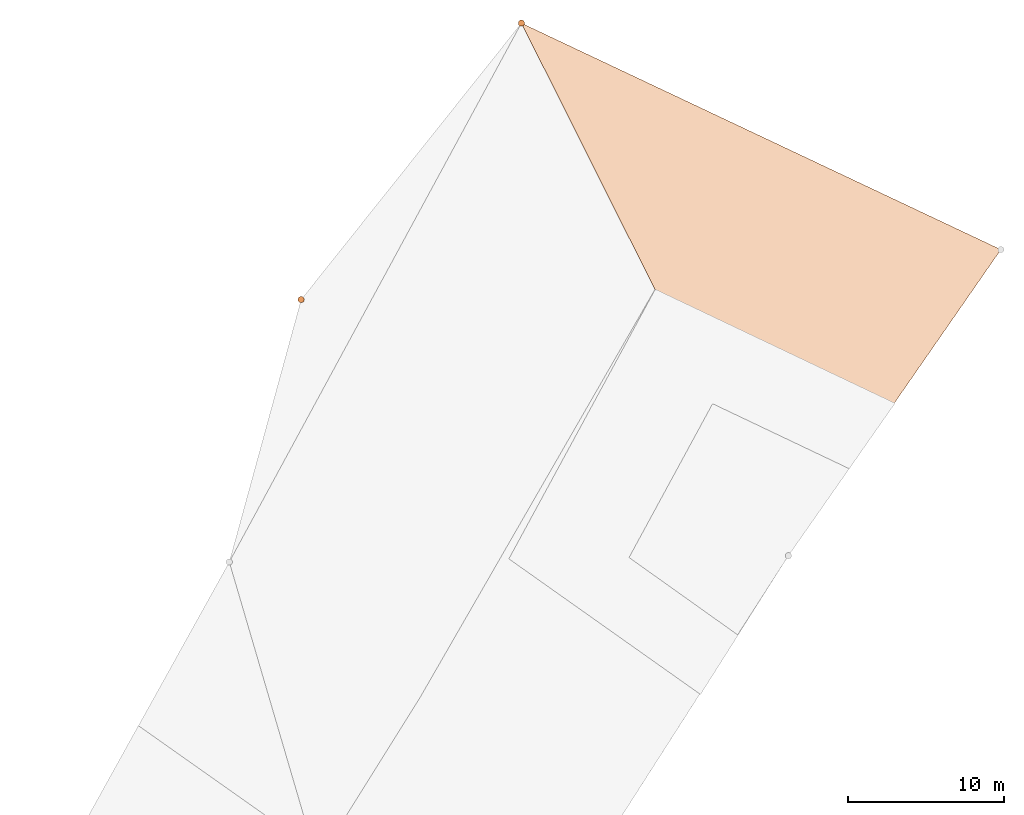
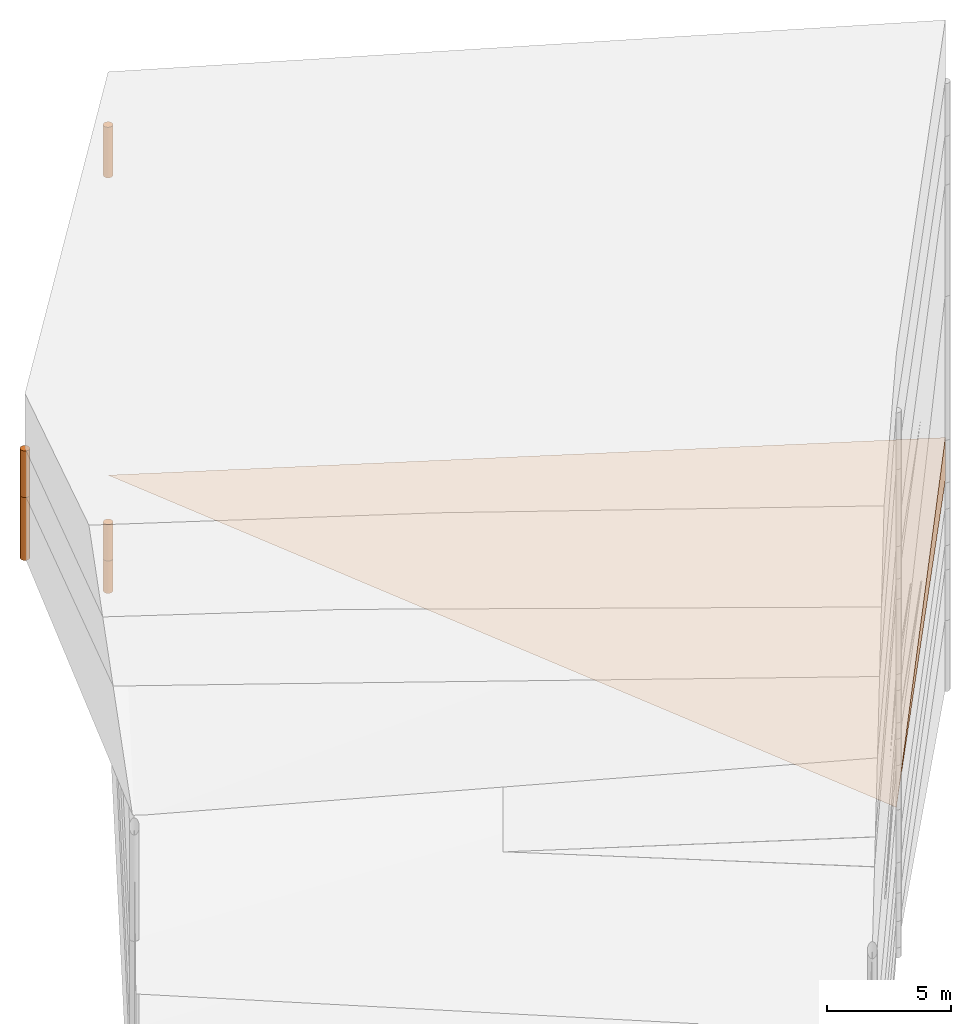
# One storey, part 17 of 24: 6 geographic elements.
"""IFC4 building model written with IfcOpenShell, lengths in metres."""

from ifc_helpers import new_model, entity, si_unit, converted_unit, frame, origin_with_axes, origin_2d_with_axis, place, context, subcontext, project, spatial, polygons, element, save


model = new_model("IFC4")

# Units and contexts
model_context = context("Model", 3, precision=1e-05, world=origin_with_axes())
plan_context = context("Plan", 2, precision=1e-05, world=origin_2d_with_axis())
body_context = subcontext(model_context, "Body", "Model", "MODEL_VIEW")
ifc_project = project(units=[converted_unit("PLANEANGLEUNIT", "degree", entity("IfcReal", 0.0174532925199433), si_unit("PLANEANGLEUNIT", "RADIAN"), dimensions=[0, 0, 0, 0, 0, 0, 0]), si_unit("AREAUNIT", "SQUARE_METRE"), si_unit("VOLUMEUNIT", "CUBIC_METRE"), si_unit("LENGTHUNIT", "METRE")], contexts=[model_context, plan_context])

# Site, building, storey
site_placement = place(None, origin_with_axes())
site = spatial("IfcSite", under=ifc_project, at=site_placement)
building_placement = place(site_placement, origin_with_axes())
building = spatial("IfcBuilding", under=site, at=building_placement, Name="Building")
storey_placement = place(building_placement, origin_with_axes())
storey = spatial("IfcBuildingStorey", under=building, at=storey_placement, Name="Storey")

# Geographic elements
geographic_element_1_placement = place(storey_placement, frame((42.3506698608398, 73.5637969970703, -2.76223611831665), z_axis=(0.0, 0.0, 1.0), x_axis=(1.0, 0.0, 0.0)))
element("IfcGeographicElement", 1, at=geographic_element_1_placement, inside=storey, PredefinedType="NOTDEFINED", context=body_context, shape_type="Tessellation", body=[
    polygons([(-22.9506683349609, 17.33620262146, 1.76223838329315), (7.74932813644409, 2.83620429039001, -0.437762945890427), (7.74932813644409, 2.83620429039001, 1.66223680973053), (-5.850670337677, -16.7637958526611, 0.0622363053262234)], [[[3, 4, 2]], [[1, 2, 4]], [[1, 4, 3]], [[2, 1, 3]]]),
])
geographic_element_2_placement = place(storey_placement, frame((5.30000019073486, 73.1999969482422, 14.8500003814697), z_axis=(0.0, 0.0, 1.0), x_axis=(1.0, 0.0, 0.0)))
element("IfcGeographicElement", 2, at=geographic_element_2_placement, inside=storey, PredefinedType="NOTDEFINED", context=body_context, shape_type="Tessellation", body=[
    polygons([(0.0, 0.0, -1.14999985694885), (0.0390180610120296, 0.196157038211823, -1.14999985694885), (0.0, 0.199999988079071, -1.14999985694885), (0.0, 0.0, 1.14999985694885), (0.0, 0.199999988079071, 1.14999985694885), (0.0390180610120296, 0.196157038211823, 1.14999985694885), (0.0765366926789284, 0.18477588891983, -1.14999985694885), (0.0765366926789284, 0.18477588891983, 1.14999985694885), (0.111114047467709, 0.166293919086456, -1.14999985694885), (0.111114047467709, 0.166293919086456, 1.14999985694885), (0.141421362757683, 0.141421362757683, -1.14999985694885), (0.141421362757683, 0.141421362757683, 1.14999985694885), (0.166293919086456, 0.111114047467709, -1.14999985694885), (0.166293919086456, 0.111114047467709, 1.14999985694885), (0.18477588891983, 0.0765366926789284, -1.14999985694885), (0.18477588891983, 0.0765366926789284, 1.14999985694885), (0.196157038211823, 0.0390180610120296, -1.14999985694885), (0.196157038211823, 0.0390180610120296, 1.14999985694885), (0.199999988079071, 0.0, -1.14999985694885), (0.199999988079071, 0.0, 1.14999985694885), (0.196157038211823, -0.0390180610120296, -1.14999985694885), (0.196157038211823, -0.0390180610120296, 1.14999985694885), (0.18477588891983, -0.0765366926789284, -1.14999985694885), (0.18477588891983, -0.0765366926789284, 1.14999985694885), (0.166293919086456, -0.111114047467709, -1.14999985694885), (0.166293919086456, -0.111114047467709, 1.14999985694885), (0.141421362757683, -0.141421362757683, -1.14999985694885), (0.141421362757683, -0.141421362757683, 1.14999985694885), (0.111114047467709, -0.166293919086456, -1.14999985694885), (0.111114047467709, -0.166293919086456, 1.14999985694885), (0.0765366926789284, -0.18477588891983, -1.14999985694885), (0.0765366926789284, -0.18477588891983, 1.14999985694885), (0.0390180610120296, -0.196157038211823, -1.14999985694885), (0.0390180610120296, -0.196157038211823, 1.14999985694885), (0.0, -0.199999988079071, -1.14999985694885), (0.0, -0.199999988079071, 1.14999985694885), (-0.0390180610120296, -0.196157038211823, -1.14999985694885), (-0.0390180610120296, -0.196157038211823, 1.14999985694885), (-0.0765366926789284, -0.18477588891983, -1.14999985694885), (-0.0765366926789284, -0.18477588891983, 1.14999985694885), (-0.111114047467709, -0.166293919086456, -1.14999985694885), (-0.111114047467709, -0.166293919086456, 1.14999985694885), (-0.141421362757683, -0.141421362757683, -1.14999985694885), (-0.141421362757683, -0.141421362757683, 1.14999985694885), (-0.166293919086456, -0.111114047467709, -1.14999985694885), (-0.166293919086456, -0.111114047467709, 1.14999985694885), (-0.18477588891983, -0.0765366926789284, -1.14999985694885), (-0.18477588891983, -0.0765366926789284, 1.14999985694885), (-0.196157038211823, -0.0390180610120296, -1.14999985694885), (-0.196157038211823, -0.0390180610120296, 1.14999985694885), (-0.199999988079071, 0.0, -1.14999985694885), (-0.199999988079071, 0.0, 1.14999985694885), (-0.196157038211823, 0.0390180610120296, -1.14999985694885), (-0.196157038211823, 0.0390180610120296, 1.14999985694885), (-0.18477588891983, 0.0765366926789284, -1.14999985694885), (-0.18477588891983, 0.0765366926789284, 1.14999985694885), (-0.166293919086456, 0.111114047467709, -1.14999985694885), (-0.166293919086456, 0.111114047467709, 1.14999985694885), (-0.141421362757683, 0.141421362757683, -1.14999985694885), (-0.141421362757683, 0.141421362757683, 1.14999985694885), (-0.111114047467709, 0.166293919086456, -1.14999985694885), (-0.111114047467709, 0.166293919086456, 1.14999985694885), (-0.0765366926789284, 0.18477588891983, -1.14999985694885), (-0.0765366926789284, 0.18477588891983, 1.14999985694885), (-0.0390180610120296, 0.196157038211823, -1.14999985694885), (-0.0390180610120296, 0.196157038211823, 1.14999985694885)], [[[3, 2, 1]], [[6, 5, 4]], [[28, 30, 29, 27]], [[2, 7, 1]], [[8, 6, 4]], [[64, 66, 65, 63]], [[7, 9, 1]], [[10, 8, 4]], [[9, 11, 1]], [[12, 10, 4]], [[6, 8, 7, 2]], [[1, 11, 13]], [[12, 4, 14]], [[66, 5, 3, 65]], [[1, 13, 15]], [[4, 16, 14]], [[12, 14, 13, 11]], [[1, 15, 17]], [[16, 4, 18]], [[14, 16, 15, 13]], [[1, 17, 19]], [[18, 4, 20]], [[16, 18, 17, 15]], [[1, 19, 21]], [[20, 4, 22]], [[18, 20, 19, 17]], [[1, 21, 23]], [[22, 4, 24]], [[20, 22, 21, 19]], [[1, 23, 25]], [[4, 26, 24]], [[22, 24, 23, 21]], [[27, 1, 25]], [[4, 28, 26]], [[24, 26, 25, 23]], [[1, 27, 29]], [[28, 4, 30]], [[26, 28, 27, 25]], [[1, 29, 31]], [[4, 32, 30]], [[5, 6, 2, 3]], [[1, 31, 33]], [[4, 34, 32]], [[30, 32, 31, 29]], [[1, 33, 35]], [[4, 36, 34]], [[8, 10, 9, 7]], [[1, 35, 37]], [[4, 38, 36]], [[32, 34, 33, 31]], [[1, 37, 39]], [[4, 40, 38]], [[36, 38, 37, 35]], [[1, 39, 41]], [[4, 42, 40]], [[38, 40, 39, 37]], [[43, 1, 41]], [[4, 44, 42]], [[40, 42, 41, 39]], [[43, 45, 1]], [[46, 44, 4]], [[42, 44, 43, 41]], [[45, 47, 1]], [[48, 46, 4]], [[44, 46, 45, 43]], [[49, 1, 47]], [[4, 50, 48]], [[46, 48, 47, 45]], [[51, 1, 49]], [[4, 52, 50]], [[48, 50, 49, 47]], [[53, 1, 51]], [[4, 54, 52]], [[50, 52, 51, 49]], [[55, 1, 53]], [[4, 56, 54]], [[52, 54, 53, 51]], [[55, 57, 1]], [[58, 56, 4]], [[54, 56, 55, 53]], [[57, 59, 1]], [[60, 58, 4]], [[56, 58, 57, 55]], [[59, 61, 1]], [[62, 60, 4]], [[58, 60, 59, 57]], [[61, 63, 1]], [[64, 62, 4]], [[60, 62, 61, 59]], [[63, 65, 1]], [[66, 64, 4]], [[62, 64, 63, 61]], [[65, 3, 1]], [[5, 66, 4]], [[34, 36, 35, 33]], [[10, 12, 11, 9]]]),
])
geographic_element_3_placement = place(storey_placement, frame((19.3999996185303, 90.9000015258789, 15.0500011444092), z_axis=(0.0, 0.0, 1.0), x_axis=(1.0, 0.0, 0.0)))
element("IfcGeographicElement", 3, at=geographic_element_3_placement, inside=storey, PredefinedType="NOTDEFINED", context=body_context, shape_type="Tessellation", body=[
    polygons([(0.0, 0.0, -1.24999988079071), (0.0390180610120296, 0.196157038211823, -1.24999988079071), (0.0, 0.199999988079071, -1.24999988079071), (0.0, 0.0, 1.24999988079071), (0.0, 0.199999988079071, 1.24999988079071), (0.0390180610120296, 0.196157038211823, 1.24999988079071), (0.0765366926789284, 0.18477588891983, -1.24999988079071), (0.0765366926789284, 0.18477588891983, 1.24999988079071), (0.111114047467709, 0.166293919086456, -1.24999988079071), (0.111114047467709, 0.166293919086456, 1.24999988079071), (0.141421362757683, 0.141421362757683, -1.24999988079071), (0.141421362757683, 0.141421362757683, 1.24999988079071), (0.166293919086456, 0.111114047467709, -1.24999988079071), (0.166293919086456, 0.111114047467709, 1.24999988079071), (0.18477588891983, 0.0765366926789284, -1.24999988079071), (0.18477588891983, 0.0765366926789284, 1.24999988079071), (0.196157038211823, 0.0390180610120296, -1.24999988079071), (0.196157038211823, 0.0390180610120296, 1.24999988079071), (0.199999988079071, 0.0, -1.24999988079071), (0.199999988079071, 0.0, 1.24999988079071), (0.196157038211823, -0.0390180610120296, -1.24999988079071), (0.196157038211823, -0.0390180610120296, 1.24999988079071), (0.18477588891983, -0.0765366926789284, -1.24999988079071), (0.18477588891983, -0.0765366926789284, 1.24999988079071), (0.166293919086456, -0.111114047467709, -1.24999988079071), (0.166293919086456, -0.111114047467709, 1.24999988079071), (0.141421362757683, -0.141421362757683, -1.24999988079071), (0.141421362757683, -0.141421362757683, 1.24999988079071), (0.111114047467709, -0.166293919086456, -1.24999988079071), (0.111114047467709, -0.166293919086456, 1.24999988079071), (0.0765366926789284, -0.18477588891983, -1.24999988079071), (0.0765366926789284, -0.18477588891983, 1.24999988079071), (0.0390180610120296, -0.196157038211823, -1.24999988079071), (0.0390180610120296, -0.196157038211823, 1.24999988079071), (0.0, -0.199999988079071, -1.24999988079071), (0.0, -0.199999988079071, 1.24999988079071), (-0.0390180610120296, -0.196157038211823, -1.24999988079071), (-0.0390180610120296, -0.196157038211823, 1.24999988079071), (-0.0765366926789284, -0.18477588891983, -1.24999988079071), (-0.0765366926789284, -0.18477588891983, 1.24999988079071), (-0.111114047467709, -0.166293919086456, -1.24999988079071), (-0.111114047467709, -0.166293919086456, 1.24999988079071), (-0.141421362757683, -0.141421362757683, -1.24999988079071), (-0.141421362757683, -0.141421362757683, 1.24999988079071), (-0.166293919086456, -0.111114047467709, -1.24999988079071), (-0.166293919086456, -0.111114047467709, 1.24999988079071), (-0.18477588891983, -0.0765366926789284, -1.24999988079071), (-0.18477588891983, -0.0765366926789284, 1.24999988079071), (-0.196157038211823, -0.0390180610120296, -1.24999988079071), (-0.196157038211823, -0.0390180610120296, 1.24999988079071), (-0.199999988079071, 0.0, -1.24999988079071), (-0.199999988079071, 0.0, 1.24999988079071), (-0.196157038211823, 0.0390180610120296, -1.24999988079071), (-0.196157038211823, 0.0390180610120296, 1.24999988079071), (-0.18477588891983, 0.0765366926789284, -1.24999988079071), (-0.18477588891983, 0.0765366926789284, 1.24999988079071), (-0.166293919086456, 0.111114047467709, -1.24999988079071), (-0.166293919086456, 0.111114047467709, 1.24999988079071), (-0.141421362757683, 0.141421362757683, -1.24999988079071), (-0.141421362757683, 0.141421362757683, 1.24999988079071), (-0.111114047467709, 0.166293919086456, -1.24999988079071), (-0.111114047467709, 0.166293919086456, 1.24999988079071), (-0.0765366926789284, 0.18477588891983, -1.24999988079071), (-0.0765366926789284, 0.18477588891983, 1.24999988079071), (-0.0390180610120296, 0.196157038211823, -1.24999988079071), (-0.0390180610120296, 0.196157038211823, 1.24999988079071)], [[[3, 2, 1]], [[6, 5, 4]], [[62, 64, 63, 61]], [[2, 7, 1]], [[8, 6, 4]], [[30, 32, 31, 29]], [[7, 9, 1]], [[10, 8, 4]], [[10, 12, 11, 9]], [[9, 11, 1]], [[12, 10, 4]], [[11, 13, 1]], [[12, 4, 14]], [[66, 5, 3, 65]], [[1, 13, 15]], [[4, 16, 14]], [[42, 44, 43, 41]], [[1, 15, 17]], [[16, 4, 18]], [[48, 50, 49, 47]], [[1, 17, 19]], [[4, 20, 18]], [[16, 18, 17, 15]], [[1, 19, 21]], [[4, 22, 20]], [[50, 52, 51, 49]], [[1, 21, 23]], [[22, 4, 24]], [[54, 56, 55, 53]], [[1, 23, 25]], [[4, 26, 24]], [[56, 58, 57, 55]], [[1, 25, 27]], [[26, 4, 28]], [[58, 60, 59, 57]], [[1, 27, 29]], [[28, 4, 30]], [[60, 62, 61, 59]], [[1, 29, 31]], [[4, 32, 30]], [[64, 66, 65, 63]], [[1, 31, 33]], [[4, 34, 32]], [[6, 8, 7, 2]], [[1, 33, 35]], [[4, 36, 34]], [[8, 10, 9, 7]], [[1, 35, 37]], [[4, 38, 36]], [[32, 34, 33, 31]], [[1, 37, 39]], [[4, 40, 38]], [[36, 38, 37, 35]], [[1, 39, 41]], [[4, 42, 40]], [[46, 48, 47, 45]], [[43, 1, 41]], [[4, 44, 42]], [[34, 36, 35, 33]], [[45, 1, 43]], [[4, 46, 44]], [[14, 16, 15, 13]], [[45, 47, 1]], [[48, 46, 4]], [[44, 46, 45, 43]], [[49, 1, 47]], [[4, 50, 48]], [[40, 42, 41, 39]], [[49, 51, 1]], [[52, 50, 4]], [[18, 20, 19, 17]], [[51, 53, 1]], [[54, 52, 4]], [[20, 22, 21, 19]], [[55, 1, 53]], [[4, 56, 54]], [[52, 54, 53, 51]], [[55, 57, 1]], [[58, 56, 4]], [[22, 24, 23, 21]], [[59, 1, 57]], [[60, 58, 4]], [[24, 26, 25, 23]], [[59, 61, 1]], [[62, 60, 4]], [[26, 28, 27, 25]], [[61, 63, 1]], [[64, 62, 4]], [[28, 30, 29, 27]], [[63, 65, 1]], [[66, 64, 4]], [[5, 6, 2, 3]], [[65, 3, 1]], [[5, 66, 4]], [[38, 40, 39, 37]], [[12, 14, 13, 11]]]),
])
geographic_element_4_placement = place(storey_placement, frame((5.30000019073486, 73.1999969482422, 12.1500015258789), z_axis=(0.0, 0.0, 1.0), x_axis=(1.0, 0.0, 0.0)))
element("IfcGeographicElement", 4, at=geographic_element_4_placement, inside=storey, PredefinedType="NOTDEFINED", context=body_context, shape_type="Tessellation", body=[
    polygons([(0.0, 0.0, -1.54999983310699), (0.0390180610120296, 0.196157038211823, -1.54999983310699), (0.0, 0.199999988079071, -1.54999983310699), (0.0, 0.0, 1.54999983310699), (0.0, 0.199999988079071, 1.54999983310699), (0.0390180610120296, 0.196157038211823, 1.54999983310699), (0.0765366926789284, 0.18477588891983, -1.54999983310699), (0.0765366926789284, 0.18477588891983, 1.54999983310699), (0.111114047467709, 0.166293919086456, -1.54999983310699), (0.111114047467709, 0.166293919086456, 1.54999983310699), (0.141421362757683, 0.141421362757683, -1.54999983310699), (0.141421362757683, 0.141421362757683, 1.54999983310699), (0.166293919086456, 0.111114047467709, -1.54999983310699), (0.166293919086456, 0.111114047467709, 1.54999983310699), (0.18477588891983, 0.0765366926789284, -1.54999983310699), (0.18477588891983, 0.0765366926789284, 1.54999983310699), (0.196157038211823, 0.0390180610120296, -1.54999983310699), (0.196157038211823, 0.0390180610120296, 1.54999983310699), (0.199999988079071, 0.0, -1.54999983310699), (0.199999988079071, 0.0, 1.54999983310699), (0.196157038211823, -0.0390180610120296, -1.54999983310699), (0.196157038211823, -0.0390180610120296, 1.54999983310699), (0.18477588891983, -0.0765366926789284, -1.54999983310699), (0.18477588891983, -0.0765366926789284, 1.54999983310699), (0.166293919086456, -0.111114047467709, -1.54999983310699), (0.166293919086456, -0.111114047467709, 1.54999983310699), (0.141421362757683, -0.141421362757683, -1.54999983310699), (0.141421362757683, -0.141421362757683, 1.54999983310699), (0.111114047467709, -0.166293919086456, -1.54999983310699), (0.111114047467709, -0.166293919086456, 1.54999983310699), (0.0765366926789284, -0.18477588891983, -1.54999983310699), (0.0765366926789284, -0.18477588891983, 1.54999983310699), (0.0390180610120296, -0.196157038211823, -1.54999983310699), (0.0390180610120296, -0.196157038211823, 1.54999983310699), (0.0, -0.199999988079071, -1.54999983310699), (0.0, -0.199999988079071, 1.54999983310699), (-0.0390180610120296, -0.196157038211823, -1.54999983310699), (-0.0390180610120296, -0.196157038211823, 1.54999983310699), (-0.0765366926789284, -0.18477588891983, -1.54999983310699), (-0.0765366926789284, -0.18477588891983, 1.54999983310699), (-0.111114047467709, -0.166293919086456, -1.54999983310699), (-0.111114047467709, -0.166293919086456, 1.54999983310699), (-0.141421362757683, -0.141421362757683, -1.54999983310699), (-0.141421362757683, -0.141421362757683, 1.54999983310699), (-0.166293919086456, -0.111114047467709, -1.54999983310699), (-0.166293919086456, -0.111114047467709, 1.54999983310699), (-0.18477588891983, -0.0765366926789284, -1.54999983310699), (-0.18477588891983, -0.0765366926789284, 1.54999983310699), (-0.196157038211823, -0.0390180610120296, -1.54999983310699), (-0.196157038211823, -0.0390180610120296, 1.54999983310699), (-0.199999988079071, 0.0, -1.54999983310699), (-0.199999988079071, 0.0, 1.54999983310699), (-0.196157038211823, 0.0390180610120296, -1.54999983310699), (-0.196157038211823, 0.0390180610120296, 1.54999983310699), (-0.18477588891983, 0.0765366926789284, -1.54999983310699), (-0.18477588891983, 0.0765366926789284, 1.54999983310699), (-0.166293919086456, 0.111114047467709, -1.54999983310699), (-0.166293919086456, 0.111114047467709, 1.54999983310699), (-0.141421362757683, 0.141421362757683, -1.54999983310699), (-0.141421362757683, 0.141421362757683, 1.54999983310699), (-0.111114047467709, 0.166293919086456, -1.54999983310699), (-0.111114047467709, 0.166293919086456, 1.54999983310699), (-0.0765366926789284, 0.18477588891983, -1.54999983310699), (-0.0765366926789284, 0.18477588891983, 1.54999983310699), (-0.0390180610120296, 0.196157038211823, -1.54999983310699), (-0.0390180610120296, 0.196157038211823, 1.54999983310699)], [[[3, 2, 1]], [[6, 5, 4]], [[32, 34, 33, 31]], [[2, 7, 1]], [[8, 6, 4]], [[64, 66, 65, 63]], [[7, 9, 1]], [[10, 8, 4]], [[9, 11, 1]], [[12, 10, 4]], [[40, 42, 41, 39]], [[1, 11, 13]], [[12, 4, 14]], [[10, 12, 11, 9]], [[1, 13, 15]], [[14, 4, 16]], [[12, 14, 13, 11]], [[1, 15, 17]], [[4, 18, 16]], [[18, 20, 19, 17]], [[1, 17, 19]], [[4, 20, 18]], [[20, 22, 21, 19]], [[1, 19, 21]], [[4, 22, 20]], [[22, 24, 23, 21]], [[1, 21, 23]], [[4, 24, 22]], [[54, 56, 55, 53]], [[1, 23, 25]], [[24, 4, 26]], [[56, 58, 57, 55]], [[1, 25, 27]], [[4, 28, 26]], [[24, 26, 25, 23]], [[1, 27, 29]], [[28, 4, 30]], [[26, 28, 27, 25]], [[1, 29, 31]], [[4, 32, 30]], [[46, 48, 47, 45]], [[1, 31, 33]], [[4, 34, 32]], [[36, 38, 37, 35]], [[1, 33, 35]], [[4, 36, 34]], [[42, 44, 43, 41]], [[1, 35, 37]], [[4, 38, 36]], [[38, 40, 39, 37]], [[1, 37, 39]], [[4, 40, 38]], [[34, 36, 35, 33]], [[1, 39, 41]], [[4, 42, 40]], [[8, 10, 9, 7]], [[43, 1, 41]], [[4, 44, 42]], [[44, 46, 45, 43]], [[43, 45, 1]], [[4, 46, 44]], [[30, 32, 31, 29]], [[47, 1, 45]], [[4, 48, 46]], [[28, 30, 29, 27]], [[47, 49, 1]], [[50, 48, 4]], [[5, 6, 2, 3]], [[49, 51, 1]], [[52, 50, 4]], [[48, 50, 49, 47]], [[51, 53, 1]], [[54, 52, 4]], [[50, 52, 51, 49]], [[53, 55, 1]], [[56, 54, 4]], [[52, 54, 53, 51]], [[57, 1, 55]], [[4, 58, 56]], [[58, 60, 59, 57]], [[59, 1, 57]], [[60, 58, 4]], [[60, 62, 61, 59]], [[59, 61, 1]], [[62, 60, 4]], [[62, 64, 63, 61]], [[61, 63, 1]], [[64, 62, 4]], [[14, 16, 15, 13]], [[63, 65, 1]], [[66, 64, 4]], [[16, 18, 17, 15]], [[65, 3, 1]], [[5, 66, 4]], [[6, 8, 7, 2]], [[66, 5, 3, 65]]]),
])
geographic_element_5_placement = place(storey_placement, frame((19.3999996185303, 90.9000015258789, -5.89999723434448), z_axis=(0.0, 0.0, 1.0), x_axis=(1.0, 0.0, 0.0)))
element("IfcGeographicElement", 5, at=geographic_element_5_placement, inside=storey, PredefinedType="NOTDEFINED", context=body_context, shape_type="Tessellation", body=[
    polygons([(0.0, 0.0, -0.79999977350235), (0.0390180610120296, 0.196157038211823, -0.79999977350235), (0.0, 0.199999988079071, -0.79999977350235), (0.0, 0.0, 0.79999977350235), (0.0, 0.199999988079071, 0.79999977350235), (0.0390180610120296, 0.196157038211823, 0.79999977350235), (0.0765366926789284, 0.18477588891983, -0.79999977350235), (0.0765366926789284, 0.18477588891983, 0.79999977350235), (0.111114047467709, 0.166293919086456, -0.79999977350235), (0.111114047467709, 0.166293919086456, 0.79999977350235), (0.141421362757683, 0.141421362757683, -0.79999977350235), (0.141421362757683, 0.141421362757683, 0.79999977350235), (0.166293919086456, 0.111114047467709, -0.79999977350235), (0.166293919086456, 0.111114047467709, 0.79999977350235), (0.18477588891983, 0.0765366926789284, -0.79999977350235), (0.18477588891983, 0.0765366926789284, 0.79999977350235), (0.196157038211823, 0.0390180610120296, -0.79999977350235), (0.196157038211823, 0.0390180610120296, 0.79999977350235), (0.199999988079071, 0.0, -0.79999977350235), (0.199999988079071, 0.0, 0.79999977350235), (0.196157038211823, -0.0390180610120296, -0.79999977350235), (0.196157038211823, -0.0390180610120296, 0.79999977350235), (0.18477588891983, -0.0765366926789284, -0.79999977350235), (0.18477588891983, -0.0765366926789284, 0.79999977350235), (0.166293919086456, -0.111114047467709, -0.79999977350235), (0.166293919086456, -0.111114047467709, 0.79999977350235), (0.141421362757683, -0.141421362757683, -0.79999977350235), (0.141421362757683, -0.141421362757683, 0.79999977350235), (0.111114047467709, -0.166293919086456, -0.79999977350235), (0.111114047467709, -0.166293919086456, 0.79999977350235), (0.0765366926789284, -0.18477588891983, -0.79999977350235), (0.0765366926789284, -0.18477588891983, 0.79999977350235), (0.0390180610120296, -0.196157038211823, -0.79999977350235), (0.0390180610120296, -0.196157038211823, 0.79999977350235), (0.0, -0.199999988079071, -0.79999977350235), (0.0, -0.199999988079071, 0.79999977350235), (-0.0390180610120296, -0.196157038211823, -0.79999977350235), (-0.0390180610120296, -0.196157038211823, 0.79999977350235), (-0.0765366926789284, -0.18477588891983, -0.79999977350235), (-0.0765366926789284, -0.18477588891983, 0.79999977350235), (-0.111114047467709, -0.166293919086456, -0.79999977350235), (-0.111114047467709, -0.166293919086456, 0.79999977350235), (-0.141421362757683, -0.141421362757683, -0.79999977350235), (-0.141421362757683, -0.141421362757683, 0.79999977350235), (-0.166293919086456, -0.111114047467709, -0.79999977350235), (-0.166293919086456, -0.111114047467709, 0.79999977350235), (-0.18477588891983, -0.0765366926789284, -0.79999977350235), (-0.18477588891983, -0.0765366926789284, 0.79999977350235), (-0.196157038211823, -0.0390180610120296, -0.79999977350235), (-0.196157038211823, -0.0390180610120296, 0.79999977350235), (-0.199999988079071, 0.0, -0.79999977350235), (-0.199999988079071, 0.0, 0.79999977350235), (-0.196157038211823, 0.0390180610120296, -0.79999977350235), (-0.196157038211823, 0.0390180610120296, 0.79999977350235), (-0.18477588891983, 0.0765366926789284, -0.79999977350235), (-0.18477588891983, 0.0765366926789284, 0.79999977350235), (-0.166293919086456, 0.111114047467709, -0.79999977350235), (-0.166293919086456, 0.111114047467709, 0.79999977350235), (-0.141421362757683, 0.141421362757683, -0.79999977350235), (-0.141421362757683, 0.141421362757683, 0.79999977350235), (-0.111114047467709, 0.166293919086456, -0.79999977350235), (-0.111114047467709, 0.166293919086456, 0.79999977350235), (-0.0765366926789284, 0.18477588891983, -0.79999977350235), (-0.0765366926789284, 0.18477588891983, 0.79999977350235), (-0.0390180610120296, 0.196157038211823, -0.79999977350235), (-0.0390180610120296, 0.196157038211823, 0.79999977350235)], [[[3, 2, 1]], [[6, 5, 4]], [[28, 30, 29, 27]], [[2, 7, 1]], [[8, 6, 4]], [[64, 66, 65, 63]], [[7, 9, 1]], [[10, 8, 4]], [[9, 11, 1]], [[12, 10, 4]], [[6, 8, 7, 2]], [[1, 11, 13]], [[12, 4, 14]], [[66, 5, 3, 65]], [[1, 13, 15]], [[4, 16, 14]], [[12, 14, 13, 11]], [[1, 15, 17]], [[16, 4, 18]], [[14, 16, 15, 13]], [[1, 17, 19]], [[4, 20, 18]], [[16, 18, 17, 15]], [[1, 19, 21]], [[4, 22, 20]], [[18, 20, 19, 17]], [[1, 21, 23]], [[22, 4, 24]], [[20, 22, 21, 19]], [[1, 23, 25]], [[4, 26, 24]], [[22, 24, 23, 21]], [[27, 1, 25]], [[4, 28, 26]], [[24, 26, 25, 23]], [[1, 27, 29]], [[28, 4, 30]], [[26, 28, 27, 25]], [[1, 29, 31]], [[4, 32, 30]], [[5, 6, 2, 3]], [[1, 31, 33]], [[4, 34, 32]], [[30, 32, 31, 29]], [[1, 33, 35]], [[4, 36, 34]], [[8, 10, 9, 7]], [[1, 35, 37]], [[4, 38, 36]], [[32, 34, 33, 31]], [[1, 37, 39]], [[4, 40, 38]], [[36, 38, 37, 35]], [[1, 39, 41]], [[4, 42, 40]], [[38, 40, 39, 37]], [[43, 1, 41]], [[4, 44, 42]], [[40, 42, 41, 39]], [[43, 45, 1]], [[46, 44, 4]], [[42, 44, 43, 41]], [[45, 47, 1]], [[48, 46, 4]], [[44, 46, 45, 43]], [[49, 1, 47]], [[4, 50, 48]], [[46, 48, 47, 45]], [[49, 51, 1]], [[52, 50, 4]], [[48, 50, 49, 47]], [[51, 53, 1]], [[54, 52, 4]], [[50, 52, 51, 49]], [[55, 1, 53]], [[4, 56, 54]], [[52, 54, 53, 51]], [[55, 57, 1]], [[58, 56, 4]], [[54, 56, 55, 53]], [[57, 59, 1]], [[60, 58, 4]], [[56, 58, 57, 55]], [[59, 61, 1]], [[62, 60, 4]], [[58, 60, 59, 57]], [[61, 63, 1]], [[64, 62, 4]], [[60, 62, 61, 59]], [[63, 65, 1]], [[66, 64, 4]], [[62, 64, 63, 61]], [[65, 3, 1]], [[5, 66, 4]], [[34, 36, 35, 33]], [[10, 12, 11, 9]]]),
])
geographic_element_6_placement = place(storey_placement, frame((19.3999996185303, 90.9000015258789, -4.19999742507935), z_axis=(0.0, 0.0, 1.0), x_axis=(1.0, 0.0, 0.0)))
element("IfcGeographicElement", 6, at=geographic_element_6_placement, inside=storey, PredefinedType="NOTDEFINED", context=body_context, shape_type="Tessellation", body=[
    polygons([(0.0, 0.0, -0.899999797344208), (0.0390180610120296, 0.196157038211823, -0.899999797344208), (0.0, 0.199999988079071, -0.899999797344208), (0.0, 0.0, 0.899999797344208), (0.0, 0.199999988079071, 0.899999797344208), (0.0390180610120296, 0.196157038211823, 0.899999797344208), (0.0765366926789284, 0.18477588891983, -0.899999797344208), (0.0765366926789284, 0.18477588891983, 0.899999797344208), (0.111114047467709, 0.166293919086456, -0.899999797344208), (0.111114047467709, 0.166293919086456, 0.899999797344208), (0.141421362757683, 0.141421362757683, -0.899999797344208), (0.141421362757683, 0.141421362757683, 0.899999797344208), (0.166293919086456, 0.111114047467709, -0.899999797344208), (0.166293919086456, 0.111114047467709, 0.899999797344208), (0.18477588891983, 0.0765366926789284, -0.899999797344208), (0.18477588891983, 0.0765366926789284, 0.899999797344208), (0.196157038211823, 0.0390180610120296, -0.899999797344208), (0.196157038211823, 0.0390180610120296, 0.899999797344208), (0.199999988079071, 0.0, -0.899999797344208), (0.199999988079071, 0.0, 0.899999797344208), (0.196157038211823, -0.0390180610120296, -0.899999797344208), (0.196157038211823, -0.0390180610120296, 0.899999797344208), (0.18477588891983, -0.0765366926789284, -0.899999797344208), (0.18477588891983, -0.0765366926789284, 0.899999797344208), (0.166293919086456, -0.111114047467709, -0.899999797344208), (0.166293919086456, -0.111114047467709, 0.899999797344208), (0.141421362757683, -0.141421362757683, -0.899999797344208), (0.141421362757683, -0.141421362757683, 0.899999797344208), (0.111114047467709, -0.166293919086456, -0.899999797344208), (0.111114047467709, -0.166293919086456, 0.899999797344208), (0.0765366926789284, -0.18477588891983, -0.899999797344208), (0.0765366926789284, -0.18477588891983, 0.899999797344208), (0.0390180610120296, -0.196157038211823, -0.899999797344208), (0.0390180610120296, -0.196157038211823, 0.899999797344208), (0.0, -0.199999988079071, -0.899999797344208), (0.0, -0.199999988079071, 0.899999797344208), (-0.0390180610120296, -0.196157038211823, -0.899999797344208), (-0.0390180610120296, -0.196157038211823, 0.899999797344208), (-0.0765366926789284, -0.18477588891983, -0.899999797344208), (-0.0765366926789284, -0.18477588891983, 0.899999797344208), (-0.111114047467709, -0.166293919086456, -0.899999797344208), (-0.111114047467709, -0.166293919086456, 0.899999797344208), (-0.141421362757683, -0.141421362757683, -0.899999797344208), (-0.141421362757683, -0.141421362757683, 0.899999797344208), (-0.166293919086456, -0.111114047467709, -0.899999797344208), (-0.166293919086456, -0.111114047467709, 0.899999797344208), (-0.18477588891983, -0.0765366926789284, -0.899999797344208), (-0.18477588891983, -0.0765366926789284, 0.899999797344208), (-0.196157038211823, -0.0390180610120296, -0.899999797344208), (-0.196157038211823, -0.0390180610120296, 0.899999797344208), (-0.199999988079071, 0.0, -0.899999797344208), (-0.199999988079071, 0.0, 0.899999797344208), (-0.196157038211823, 0.0390180610120296, -0.899999797344208), (-0.196157038211823, 0.0390180610120296, 0.899999797344208), (-0.18477588891983, 0.0765366926789284, -0.899999797344208), (-0.18477588891983, 0.0765366926789284, 0.899999797344208), (-0.166293919086456, 0.111114047467709, -0.899999797344208), (-0.166293919086456, 0.111114047467709, 0.899999797344208), (-0.141421362757683, 0.141421362757683, -0.899999797344208), (-0.141421362757683, 0.141421362757683, 0.899999797344208), (-0.111114047467709, 0.166293919086456, -0.899999797344208), (-0.111114047467709, 0.166293919086456, 0.899999797344208), (-0.0765366926789284, 0.18477588891983, -0.899999797344208), (-0.0765366926789284, 0.18477588891983, 0.899999797344208), (-0.0390180610120296, 0.196157038211823, -0.899999797344208), (-0.0390180610120296, 0.196157038211823, 0.899999797344208)], [[[3, 2, 1]], [[6, 5, 4]], [[28, 30, 29, 27]], [[2, 7, 1]], [[8, 6, 4]], [[64, 66, 65, 63]], [[7, 9, 1]], [[10, 8, 4]], [[9, 11, 1]], [[12, 10, 4]], [[6, 8, 7, 2]], [[1, 11, 13]], [[12, 4, 14]], [[66, 5, 3, 65]], [[1, 13, 15]], [[4, 16, 14]], [[12, 14, 13, 11]], [[1, 15, 17]], [[4, 18, 16]], [[14, 16, 15, 13]], [[1, 17, 19]], [[4, 20, 18]], [[16, 18, 17, 15]], [[1, 19, 21]], [[4, 22, 20]], [[18, 20, 19, 17]], [[1, 21, 23]], [[22, 4, 24]], [[20, 22, 21, 19]], [[1, 23, 25]], [[4, 26, 24]], [[22, 24, 23, 21]], [[1, 25, 27]], [[4, 28, 26]], [[24, 26, 25, 23]], [[1, 27, 29]], [[28, 4, 30]], [[26, 28, 27, 25]], [[1, 29, 31]], [[4, 32, 30]], [[5, 6, 2, 3]], [[1, 31, 33]], [[4, 34, 32]], [[30, 32, 31, 29]], [[1, 33, 35]], [[4, 36, 34]], [[8, 10, 9, 7]], [[1, 35, 37]], [[4, 38, 36]], [[32, 34, 33, 31]], [[1, 37, 39]], [[4, 40, 38]], [[36, 38, 37, 35]], [[1, 39, 41]], [[4, 42, 40]], [[38, 40, 39, 37]], [[43, 1, 41]], [[4, 44, 42]], [[40, 42, 41, 39]], [[43, 45, 1]], [[4, 46, 44]], [[42, 44, 43, 41]], [[45, 47, 1]], [[48, 46, 4]], [[44, 46, 45, 43]], [[49, 1, 47]], [[50, 48, 4]], [[46, 48, 47, 45]], [[49, 51, 1]], [[52, 50, 4]], [[48, 50, 49, 47]], [[51, 53, 1]], [[54, 52, 4]], [[50, 52, 51, 49]], [[53, 55, 1]], [[4, 56, 54]], [[52, 54, 53, 51]], [[55, 57, 1]], [[58, 56, 4]], [[54, 56, 55, 53]], [[59, 1, 57]], [[60, 58, 4]], [[56, 58, 57, 55]], [[59, 61, 1]], [[62, 60, 4]], [[58, 60, 59, 57]], [[61, 63, 1]], [[64, 62, 4]], [[60, 62, 61, 59]], [[63, 65, 1]], [[66, 64, 4]], [[62, 64, 63, 61]], [[65, 3, 1]], [[5, 66, 4]], [[34, 36, 35, 33]], [[10, 12, 11, 9]]]),
])

save(model, "model.ifc")
